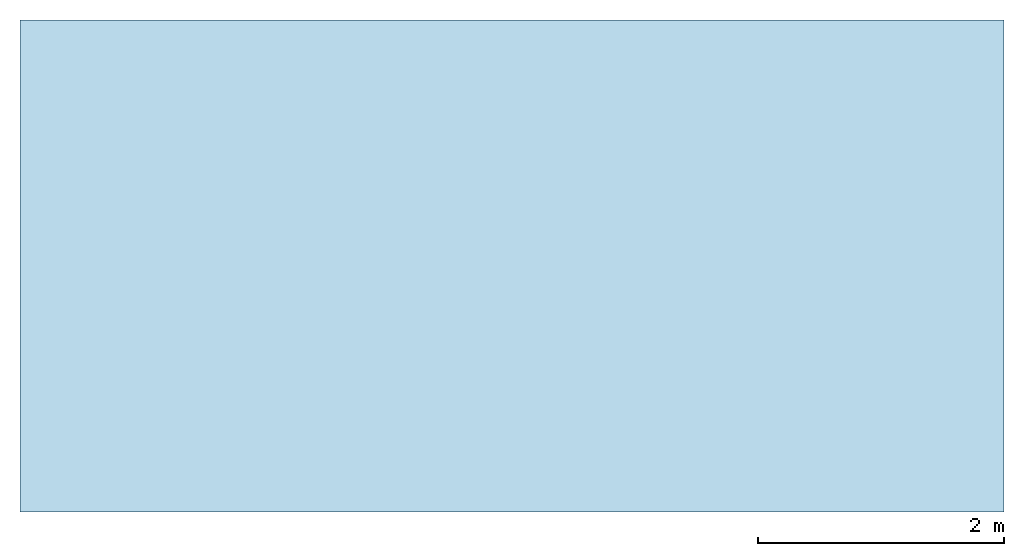
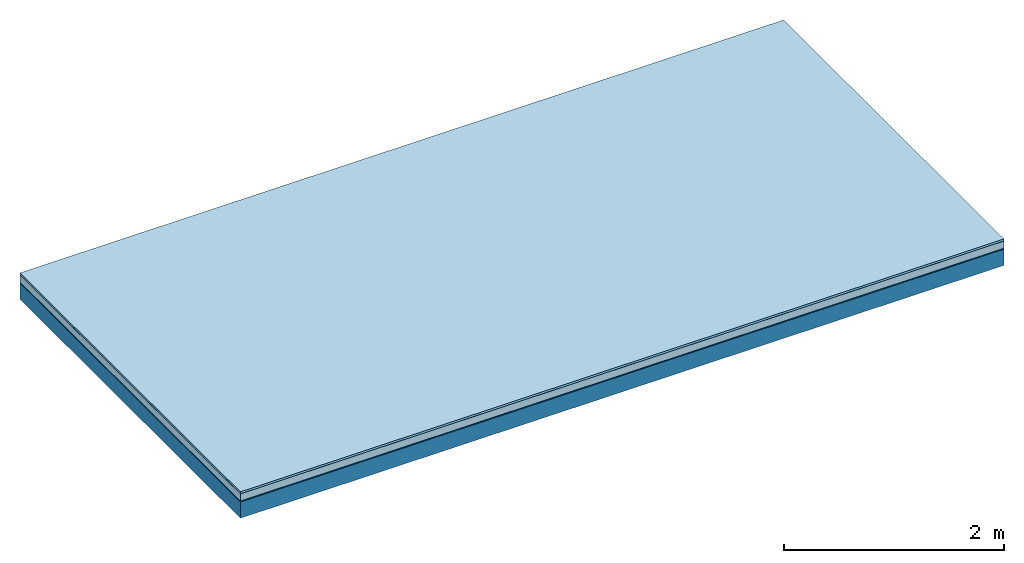
# One storey: 5 plates, 1 member, 1 element without a shape of its own.
"""IFC4 building model written with IfcOpenShell, lengths in metres."""

import ifcopenshell
import ifcopenshell.guid

model = None  # the IFC model being written
_history = None  # IfcOwnerHistory: only IFC2X3 demands one
_inside = {}  # id of a spatial element -> (the spatial element, [elements in it])
_under = {}  # id of a project, library or spatial element -> (it, [spatial elements below it])
_declared = {}  # id of a project -> (the project, [libraries it declares])
_typed = {}  # id of a type object -> (the type object, [elements of that type])
_made_of = {}  # id of a material, layer set ... -> (it, [elements and type objects made of it])


def new_model(schema):
    """Start an empty IFC model of exactly this schema.

    Asked for "IFC4X3", IfcOpenShell would pick the latest addendum, in which some entities
    have other attributes; the version numbers below select the first issue.
    IFC2X3 requires an IfcOwnerHistory on every rooted entity: one is made here for all.
    """
    global model, _history
    if schema == "IFC4X3":
        model = ifcopenshell.file(schema_version=(4, 3, 0, 0))
    else:
        model = ifcopenshell.file(schema=schema)
    _inside.clear()
    _under.clear()
    _declared.clear()
    _typed.clear()
    _made_of.clear()
    _history = None
    if model.schema == "IFC2X3":
        org = make("IfcOrganization", Name="unknown")
        user = make(
            "IfcPersonAndOrganization",
            ThePerson=make("IfcPerson", FamilyName="unknown"),
            TheOrganization=org,
        )
        app = make(
            "IfcApplication",
            ApplicationDeveloper=org,
            Version="unknown",
            ApplicationFullName="unknown",
            ApplicationIdentifier="unknown",
        )
        _history = make(
            "IfcOwnerHistory",
            OwningUser=user,
            OwningApplication=app,
            ChangeAction="ADDED",
            CreationDate=0,
        )
    return model


def make(cls, **values):
    """One entity of the class cls with the attributes given. An attribute that is None is left unset."""
    return model.create_entity(
        cls, **{name: value for name, value in values.items() if value is not None}
    )


def rooted(cls, **values):
    """An entity with a GlobalId (a new one), such as an element, a storey or a relation."""
    return make(cls, GlobalId=ifcopenshell.guid.new(), OwnerHistory=_history, **values)


def si_unit(unit_type, name, prefix=None):
    """IfcSIUnit, for example si_unit("LENGTHUNIT", "METRE", prefix="MILLI")."""
    return make("IfcSIUnit", UnitType=unit_type, Prefix=prefix, Name=name)


def derived_unit(unit_type, elements):
    """IfcDerivedUnit: a product of units, each with its exponent."""
    return make(
        "IfcDerivedUnit",
        Elements=[
            make("IfcDerivedUnitElement", Unit=unit, Exponent=power)
            for unit, power in elements
        ],
        UnitType=unit_type,
    )


def assignment(units):
    """IfcUnitAssignment: the units of a project."""
    return None if units is None else make("IfcUnitAssignment", Units=units)


def point(xyz):
    """IfcCartesianPoint."""
    return None if xyz is None else make("IfcCartesianPoint", Coordinates=xyz)


def direction(xyz):
    """IfcDirection."""
    return None if xyz is None else make("IfcDirection", DirectionRatios=xyz)


def frame(location, z_axis=None, x_axis=None):
    """IfcAxis2Placement3D, a coordinate frame: its origin and axes. An axis left out is left unset."""
    return make(
        "IfcAxis2Placement3D",
        Location=point(location),
        Axis=direction(z_axis),
        RefDirection=direction(x_axis),
    )


def frame_2d(location, x_axis=None):
    """IfcAxis2Placement2D, a coordinate frame in the plane: its origin and x axis."""
    return make(
        "IfcAxis2Placement2D", Location=point(location), RefDirection=direction(x_axis)
    )


def origin():
    """The frame at (0, 0, 0) with its axes left unset."""
    return frame((0.0, 0.0, 0.0))


def origin_with_axes():
    """The frame at (0, 0, 0) with the z axis (0, 0, 1) and the x axis (1, 0, 0) written out."""
    return frame((0.0, 0.0, 0.0), z_axis=(0.0, 0.0, 1.0), x_axis=(1.0, 0.0, 0.0))


def place(relative_to, where):
    """IfcLocalPlacement: puts the frame where relative to a parent placement (None: the world)."""
    return make(
        "IfcLocalPlacement", PlacementRelTo=relative_to, RelativePlacement=where
    )


def context(
    kind, dimensions, precision=None, world=None, true_north=None, identifier=None
):
    """IfcGeometricRepresentationContext, for example the 3D "Model" context."""
    return make(
        "IfcGeometricRepresentationContext",
        ContextIdentifier=identifier,
        ContextType=kind,
        CoordinateSpaceDimension=dimensions,
        Precision=precision,
        WorldCoordinateSystem=world,
        TrueNorth=true_north,
    )


def project(units=None, contexts=None):
    """IfcProject with its units and contexts."""
    return rooted(
        "IfcProject",
        Name="project",
        RepresentationContexts=contexts,
        UnitsInContext=assignment(units),
    )


def spatial(cls, under=None, at=None, **own):
    """A site, building, storey or space (cls), placed at a placement, below another one or the project."""
    s = rooted(cls, ObjectPlacement=at, **own)
    if under is not None:
        _under.setdefault(under.id(), (under, []))[1].append(s)
    return s


def profile(cls, at=None, kind="AREA", **sizes):
    """A parametric profile (cls). Its sizes go by their IFC names, for example OverallWidth=200.0."""
    return make(cls, ProfileType=kind, Position=at, **sizes)


def rectangle(**sizes):
    """IfcRectangleProfileDef."""
    return profile("IfcRectangleProfileDef", **sizes)


def extrude(swept, where, along, depth):
    """IfcExtrudedAreaSolid: the profile swept, set in the frame where, extruded along a direction by depth."""
    return make(
        "IfcExtrudedAreaSolid",
        SweptArea=swept,
        Position=where,
        ExtrudedDirection=direction(along),
        Depth=depth,
    )


def shape(context_of_items, identifier, shape_type, items):
    """IfcShapeRepresentation: the items that make up one representation, for example the "Body"."""
    return make(
        "IfcShapeRepresentation",
        ContextOfItems=context_of_items,
        RepresentationIdentifier=identifier,
        RepresentationType=shape_type,
        Items=items,
    )


def material(Name=None, Category=None):
    """IfcMaterial."""
    return make("IfcMaterial", Name=Name, Category=Category)


def layer(
    of_material, thickness, ventilated=None, Name=None, Category=None, Priority=None
):
    """IfcMaterialLayer: one layer of a wall or slab, of a material (None: an air gap)."""
    return make(
        "IfcMaterialLayer",
        Material=of_material,
        LayerThickness=thickness,
        IsVentilated=ventilated,
        Name=Name,
        Category=Category,
        Priority=Priority,
    )


def layer_set(layers, Name=None):
    """IfcMaterialLayerSet."""
    return make("IfcMaterialLayerSet", MaterialLayers=layers, LayerSetName=Name)


def made_of(thing, what):
    """Note that an element or type object is made of a material, layer set ...; save() writes the relation."""
    if what is not None:
        _made_of.setdefault(what.id(), (what, []))[1].append(thing)
    return thing


def type_object(cls, material=None, **own):
    """A type object (cls), such as IfcWallType, which elements share."""
    return made_of(rooted(cls, **own), material)


def element(
    cls,
    number,
    at=None,
    inside=None,
    cuts=None,
    type_object=None,
    material=None,
    context=None,
    identifier="Body",
    shape_type=None,
    held_by="IfcProductDefinitionShape",
    body=None,
    shapes=None,
    **own,
):
    """One element of the class cls, such as IfcWall. Its Tag is "e" and its number.

    at: its placement. inside: the storey or other place that contains it. cuts: it is an
    opening in that element (IfcRelVoidsElement). A single representation is given by context,
    identifier, shape_type and body (its items); several are given by shapes. held_by: the class
    of the entity that holds the representations. save() writes the other relations.
    """
    e = rooted(cls, Tag="e%d" % number, ObjectPlacement=at, **own)
    if body is not None:
        shapes = [shape(context, identifier, shape_type, body)]
    if shapes is not None:
        e.Representation = make(held_by, Representations=shapes)
    if inside is not None:
        _inside.setdefault(inside.id(), (inside, []))[1].append(e)
    if cuts is not None:
        rooted(
            "IfcRelVoidsElement", RelatingBuildingElement=cuts, RelatedOpeningElement=e
        )
    if type_object is not None:
        _typed.setdefault(type_object.id(), (type_object, []))[1].append(e)
    return made_of(e, material)


def aggregate(whole, parts):
    """IfcRelAggregates: a whole, such as a stair, and the parts it consists of."""
    return rooted("IfcRelAggregates", RelatingObject=whole, RelatedObjects=parts)


def save(model, path):
    """Write the relations noted so far, then the file.

    IfcRelAggregates (storeys below a building ...), IfcRelContainedInSpatialStructure (elements
    in a storey), IfcRelDefinesByType, IfcRelAssociatesMaterial and IfcRelDeclares: one each for
    every whole, place, type object, material and project.
    """
    for whole, parts in _under.values():
        aggregate(whole, parts)
    for where, things in _inside.values():
        rooted(
            "IfcRelContainedInSpatialStructure",
            RelatedElements=things,
            RelatingStructure=where,
        )
    for kind, things in _typed.values():
        rooted("IfcRelDefinesByType", RelatedObjects=things, RelatingType=kind)
    for what, things in _made_of.values():
        rooted("IfcRelAssociatesMaterial", RelatedObjects=things, RelatingMaterial=what)
    for by, libraries in _declared.values():
        rooted("IfcRelDeclares", RelatingContext=by, RelatedDefinitions=libraries)
    model.write(path)


model = new_model("IFC4")

# Units and contexts
plan_context = context("Plan", 3, precision=1e-05, world=origin(), true_north=direction((0.0, 1.0)))
model_context = context("Model", 3, precision=1e-05, world=origin(), true_north=direction((0.0, 1.0)))
ifc_project = project(units=[si_unit("LENGTHUNIT", "METRE"), derived_unit("SOUNDPRESSUREUNIT", [(si_unit("PRESSUREUNIT", "PASCAL", prefix="MICRO"), 0)]), si_unit("ENERGYUNIT", "JOULE", prefix="MEGA"), si_unit("MASSUNIT", "GRAM", prefix="KILO"), derived_unit("THERMALTRANSMITTANCEUNIT", [(si_unit("POWERUNIT", "WATT"), 1), (si_unit("AREAUNIT", "SQUARE_METRE"), -1), (si_unit("THERMODYNAMICTEMPERATUREUNIT", "KELVIN"), -1)]), derived_unit("AREADENSITYUNIT", [(si_unit("MASSUNIT", "GRAM", prefix="KILO"), 1), (si_unit("AREAUNIT", "SQUARE_METRE"), -1)]), derived_unit("USERDEFINED", [(si_unit("ENERGYUNIT", "JOULE", prefix="MEGA"), 1), (si_unit("AREAUNIT", "SQUARE_METRE"), -1)])], contexts=[plan_context, model_context])

# Site, building, storey
site = spatial("IfcSite", under=ifc_project)
building_placement = place(None, origin())
building = spatial("IfcBuilding", under=site, at=building_placement)
storey_placement = place(building_placement, origin())
storey = spatial("IfcBuildingStorey", under=building, at=storey_placement)

# Slab, member, plates
ifc_material_1 = material(Name="with tongue and groove", Category="07.009")
ifc_layer_1 = layer(ifc_material_1, 0.022, Name="Flooring")
ifc_material_2 = material(Category="09.006")
ifc_layer_2 = layer(ifc_material_2, 0.0005, Name="layer")
ifc_material_3 = material(Category="07.011")
ifc_layer_3 = layer(ifc_material_3, 0.08, Name="On-material")
ifc_material_4 = material(Name="Wood fiber generic product", Category="10.009")
ifc_layer_4 = layer(ifc_material_4, 0.01, Name="Impact sound insulation")
ifc_material_5 = material(Name="protection", Category="09.007")
ifc_layer_5 = layer(ifc_material_5, 0.0005, Name="Sub-floor")
ifc_material_6 = material(Name="no composite action")
ifc_layer_6 = layer(ifc_material_6, 0.0, Name="Bond")
ifc_layer_7 = layer(None, 0.18, Name="Supporting structure")
ifc_layer_set = layer_set([ifc_layer_1, ifc_layer_2, ifc_layer_3, ifc_layer_4, ifc_layer_5, ifc_layer_6, ifc_layer_7])
slab_type = type_object("IfcSlabType", Name="A2018", PredefinedType="NOTDEFINED", material=ifc_layer_set)
slab_placement = place(None, frame((0.0, 0.0, 0.0), z_axis=(0.0, 0.0, -1.0), x_axis=(1.0, 0.0, 0.0)))
slab = element("IfcSlab", 1, at=slab_placement, inside=storey, type_object=slab_type, material=ifc_layer_set, Name="Slab #1")
ifc_material_7 = material(Name="Solid timber panel")
member_placement = place(slab_placement, origin())
member = element("IfcMember", 2, at=member_placement, material=ifc_material_7, Name="Supporting structure", context=plan_context, shape_type="SweptSolid", body=[
    extrude(rectangle(XDim=1.0, YDim=0.18, at=frame_2d((0.5, 0.09), x_axis=(1.0, 0.0))), frame((0.0, 4.0, 0.113), z_axis=(0.0, -1.0, 0.0), x_axis=(1.0, 0.0, 0.0)), (0.0, 0.0, 1.0), 4.0),
    extrude(rectangle(XDim=1.0, YDim=0.18, at=frame_2d((0.5, 0.09), x_axis=(1.0, 0.0))), frame((1.0, 4.0, 0.113), z_axis=(0.0, -1.0, 0.0), x_axis=(1.0, 0.0, 0.0)), (0.0, 0.0, 1.0), 4.0),
    extrude(rectangle(XDim=1.0, YDim=0.18, at=frame_2d((0.5, 0.09), x_axis=(1.0, 0.0))), frame((2.0, 4.0, 0.113), z_axis=(0.0, -1.0, 0.0), x_axis=(1.0, 0.0, 0.0)), (0.0, 0.0, 1.0), 4.0),
    extrude(rectangle(XDim=1.0, YDim=0.18, at=frame_2d((0.5, 0.09), x_axis=(1.0, 0.0))), frame((3.0, 4.0, 0.113), z_axis=(0.0, -1.0, 0.0), x_axis=(1.0, 0.0, 0.0)), (0.0, 0.0, 1.0), 4.0),
    extrude(rectangle(XDim=1.0, YDim=0.18, at=frame_2d((0.5, 0.09), x_axis=(1.0, 0.0))), frame((4.0, 4.0, 0.113), z_axis=(0.0, -1.0, 0.0), x_axis=(1.0, 0.0, 0.0)), (0.0, 0.0, 1.0), 4.0),
    extrude(rectangle(XDim=1.0, YDim=0.18, at=frame_2d((0.5, 0.09), x_axis=(1.0, 0.0))), frame((5.0, 4.0, 0.113), z_axis=(0.0, -1.0, 0.0), x_axis=(1.0, 0.0, 0.0)), (0.0, 0.0, 1.0), 4.0),
    extrude(rectangle(XDim=1.0, YDim=0.18, at=frame_2d((0.5, 0.09), x_axis=(1.0, 0.0))), frame((6.0, 4.0, 0.113), z_axis=(0.0, -1.0, 0.0), x_axis=(1.0, 0.0, 0.0)), (0.0, 0.0, 1.0), 4.0),
    extrude(rectangle(XDim=1.0, YDim=0.18, at=frame_2d((0.5, 0.09), x_axis=(1.0, 0.0))), frame((7.0, 4.0, 0.113), z_axis=(0.0, -1.0, 0.0), x_axis=(1.0, 0.0, 0.0)), (0.0, 0.0, 1.0), 4.0),
])
plate_1_placement = place(slab_placement, origin())
plate_1 = element("IfcPlate", 3, at=plate_1_placement, material=ifc_material_1, Name="Flooring", context=plan_context, shape_type="SweptSolid", body=[
    extrude(rectangle(XDim=8.0, YDim=4.0, at=frame_2d((4.0, 2.0), x_axis=(1.0, 0.0))), origin_with_axes(), (0.0, 0.0, 1.0), 0.022),
])
plate_2_placement = place(slab_placement, origin())
plate_2 = element("IfcPlate", 4, at=plate_2_placement, material=ifc_material_2, Name="layer", context=plan_context, shape_type="SweptSolid", body=[
    extrude(rectangle(XDim=8.0, YDim=4.0, at=frame_2d((4.0, 2.0), x_axis=(1.0, 0.0))), frame((0.0, 0.0, 0.022), z_axis=(0.0, 0.0, 1.0), x_axis=(1.0, 0.0, 0.0)), (0.0, 0.0, 1.0), 0.0005),
])
plate_3_placement = place(slab_placement, origin())
plate_3 = element("IfcPlate", 5, at=plate_3_placement, material=ifc_material_3, Name="On-material", context=plan_context, shape_type="SweptSolid", body=[
    extrude(rectangle(XDim=8.0, YDim=4.0, at=frame_2d((4.0, 2.0), x_axis=(1.0, 0.0))), frame((0.0, 0.0, 0.0225), z_axis=(0.0, 0.0, 1.0), x_axis=(1.0, 0.0, 0.0)), (0.0, 0.0, 1.0), 0.08),
])
plate_4_placement = place(slab_placement, origin())
plate_4 = element("IfcPlate", 6, at=plate_4_placement, material=ifc_material_4, Name="Impact sound insulation", context=plan_context, shape_type="SweptSolid", body=[
    extrude(rectangle(XDim=8.0, YDim=4.0, at=frame_2d((4.0, 2.0), x_axis=(1.0, 0.0))), frame((0.0, 0.0, 0.1025), z_axis=(0.0, 0.0, 1.0), x_axis=(1.0, 0.0, 0.0)), (0.0, 0.0, 1.0), 0.01),
])
plate_5_placement = place(slab_placement, origin())
plate_5 = element("IfcPlate", 7, at=plate_5_placement, material=ifc_material_5, Name="Sub-floor", context=plan_context, shape_type="SweptSolid", body=[
    extrude(rectangle(XDim=8.0, YDim=4.0, at=frame_2d((4.0, 2.0), x_axis=(1.0, 0.0))), frame((0.0, 0.0, 0.1125), z_axis=(0.0, 0.0, 1.0), x_axis=(1.0, 0.0, 0.0)), (0.0, 0.0, 1.0), 0.0005),
])
aggregate(slab, [plate_1, plate_2, plate_3, plate_4, plate_5, member])

save(model, "model.ifc")
